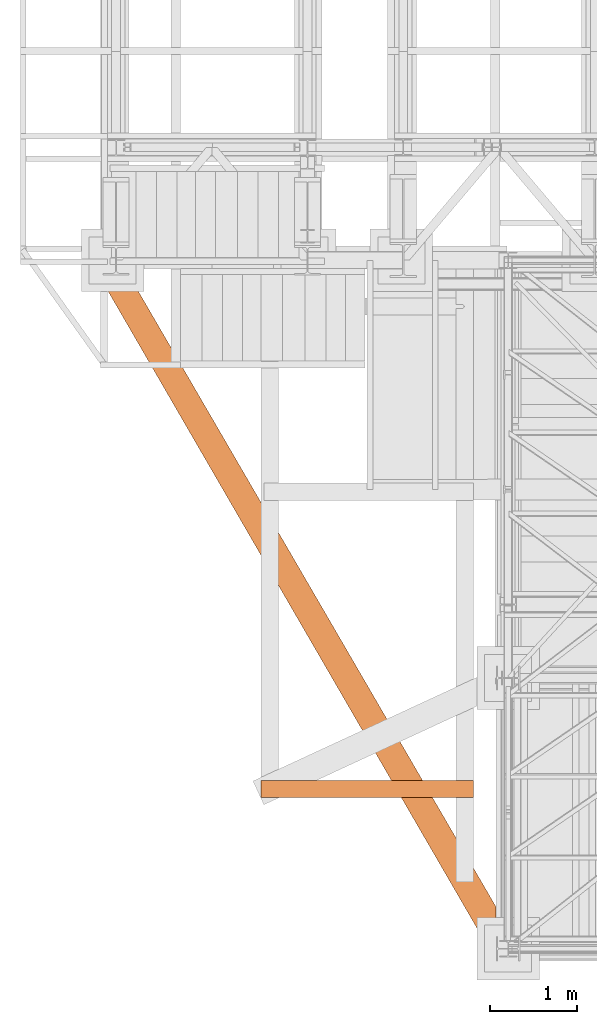
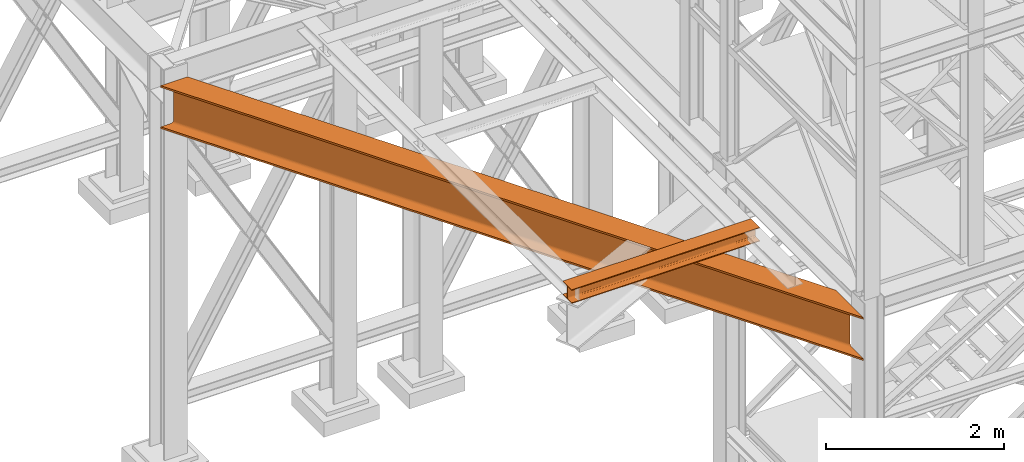
# One storey, part 1 of 208: 2 proxies.
"""IFC2X3 building model written with IfcOpenShell, lengths in millimetres."""

from ifc_helpers import new_model, entity, si_unit, converted_unit, frame, origin, origin_with_axes, place, context, subcontext, project, spatial, faceted_brep, element, save


model = new_model("IFC2X3")

# Units and contexts
model_context = context("Model", 3, precision=1e-05, world=origin())
plan_context = context("Plan", 3, precision=1e-05, world=origin())
body_context = subcontext(model_context, "Body", "Model", "MODEL_VIEW")
ifc_project = project(units=[si_unit("LENGTHUNIT", "METRE", prefix="MILLI"), converted_unit("PLANEANGLEUNIT", "DEGREE", entity("IfcPlaneAngleMeasure", 0.0174532925199433), si_unit("PLANEANGLEUNIT", "RADIAN"), dimensions=[0, 0, 0, 0, 0, 0, 0]), si_unit("AREAUNIT", "SQUARE_METRE"), si_unit("VOLUMEUNIT", "CUBIC_METRE")], contexts=[model_context, plan_context])

# Building, storey
building_placement = place(None, origin())
building = spatial("IfcBuilding", under=ifc_project, at=building_placement, CompositionType="COMPLEX")
storey_placement = place(building_placement, origin_with_axes())
storey = spatial("IfcBuildingStorey", under=building, at=storey_placement, Name="Geschoss", CompositionType="ELEMENT")

# Proxies
proxy_1_placement = place(storey_placement, frame((-3505.997718269851, -25312.57439091394, 4504.990005364415), z_axis=(0.0, 0.0, 1.0), x_axis=(1.0, 0.0, 0.0)))
element("IfcBuildingElementProxy", 1, at=proxy_1_placement, inside=storey, context=body_context, shape_type="Brep", body=[
    faceted_brep([(4564.262686202468, 622.7829206339375, 590.0100000000002), (346.9211581445925, 7880.009995598281, 590.0100000000002), (346.9211581445925, 7880.009995598281, 565.0100000000002), (4564.262686202468, 622.7829206339375, 565.0100000000002), (4564.262686202468, 622.7829206339375, 565.0100000000002), (346.9211581445925, 7880.009995598281, 565.0100000000002), (212.1356261913879, 7880.009995598281, 565.0100000000002), (4564.262686202468, 380.9394364544241, 565.0100000000002), (4564.262686202468, 380.9394364544241, 565.0100000000002), (212.1356261913879, 7880.009995598281, 565.0100000000002), (202.5987725171945, 7880.009995598281, 563.7032507142912), (4564.262686202468, 363.6192277572482, 563.6884339422604), (202.486086011646, 7880.009995598281, 563.6884339422604), (193.8785687326563, 7880.009995598281, 559.8945001282118), (4564.262686202468, 347.9943855320853, 559.8534254634023), (193.7814637785159, 7880.009995598281, 559.8534254634023), (186.9478919928752, 7880.009995598281, 553.9417684022137), (4564.262686202468, 335.5944568794512, 553.8801750658013), (186.8737043222827, 7880.009995598281, 553.8801750658013), (182.4852673949699, 7880.009995598281, 546.4290967956804), (4564.262686202469, 327.6333254426718, 546.3534305458606), (182.4388328598234, 7880.009995598281, 546.3534305458606), (180.9264244528931, 7880.009995598281, 538.0930942108116), (4564.262686202468, 324.8898735973708, 538.0100000000002), (180.9105722931872, 7880.009995598281, 538.0100000000002), (180.9105722931872, 7880.009995598281, 52.01000000000022), (4564.262686202468, 324.8898735973708, 52.01000000000022), (4564.262686202468, 324.8898735973708, 52.01000000000022), (180.9105722931872, 7880.009995598281, 52.01000000000022), (182.4228536955015, 7880.009995598281, 43.75032818788168), (4564.262686202469, 327.6333254426718, 43.66656945413979), (182.4388328598234, 7880.009995598281, 43.66656945413979), (186.8262006717232, 7880.009995598281, 36.21723007892069), (4564.262686202468, 335.5944568794512, 36.13982493419917), (186.8737043222827, 7880.009995598281, 36.13982493419917), (193.7046841579395, 7880.009995598281, 30.23031562115921), (4564.262686202469, 347.9943855320853, 30.16657453659809), (193.7814637785159, 7880.009995598281, 30.16657453659809), (202.384869361942, 7880.009995598281, 26.37437638797292), (4564.262686202468, 363.6192277572482, 26.33156605774093), (202.486086011646, 7880.009995598281, 26.33156605774093), (212.0178928223504, 7880.009995598281, 25.02547893943847), (4564.262686202468, 380.9394364544241, 25.01000000000022), (212.1356261913879, 7880.009995598281, 25.01000000000022), (346.9211581445925, 7880.009995598281, 25.01000000000022), (4564.262686202468, 622.7829206339411, 25.01000000000022), (4564.262686202468, 622.7829206339411, 25.01000000000022), (346.9211581445925, 7880.009995598281, 25.01000000000022), (346.9211581445925, 7880.009995598281, 0.01000000000021828), (4564.262686202468, 622.7829206339375, 0.01000000000021828), (4564.262686202468, 622.7829206339375, 0.01000000000021828), (346.9211581445925, 7880.009995598281, 0.01000000000021828), (0.01000000000021828, 7880.009995598281, 0.01000000000021828), (4564.262686202468, 0.01000000000203727, 0.01000000000021828), (4564.262686202468, 0.01000000000203727, 0.01000000000021828), (0.01000000000021828, 7880.009995598281, 0.01000000000021828), (0.01000000000021828, 7880.009995598281, 25.01000000000022), (4564.262686202468, 0.01000000000203727, 25.01000000000022), (4564.262686202468, 0.01000000000203727, 25.01000000000022), (0.01000000000021828, 7880.009995598281, 25.01000000000022), (134.6597476393436, 7880.009995598281, 25.01000000000022), (4564.262686202468, 241.8534841795117, 25.01000000000022), (4564.262686202468, 241.8534841795117, 25.01000000000022), (134.6597476393436, 7880.009995598281, 25.01000000000022), (144.2271042825123, 7880.009995598281, 26.32116263985427), (4564.262686202469, 259.1736928766877, 26.33156605774093), (144.3061822778, 7880.009995598281, 26.33156605774093), (152.9329818816095, 7880.009995598281, 30.13450818402725), (4564.262686202468, 274.7985351018506, 30.16657453659809), (153.0087610158716, 7880.009995598281, 30.16657453659809), (159.8524497735762, 7880.009995598281, 36.08753934009383), (4564.262686202468, 287.1984637544883, 36.13982493419917), (159.9154104590762, 7880.009995598281, 36.13982493419917), (164.308205835936, 7880.009995598281, 43.59876618566887), (4564.262686202469, 295.1595951912641, 43.66656945413979), (164.3498079410019, 7880.009995598281, 43.66656945413979), (165.863464784421, 7880.009995598281, 51.93406860522919), (4564.262686202468, 297.9030470365688, 52.01000000000113), (165.8779484128099, 7880.009995598281, 52.01000000000113), (165.8779484128118, 7880.009995598281, 538.0100000000002), (4564.262686202468, 297.9030470365688, 538.0100000000002), (4564.262686202468, 297.9030470365688, 538.0100000000002), (165.8779484128118, 7880.009995598281, 538.0100000000002), (164.3641643242863, 7880.009995598281, 546.2781651586538), (4564.262686202468, 295.1595951912677, 546.3534305458606), (164.3498079410019, 7880.009995598281, 546.3534305458606), (159.95594069441, 7880.009995598281, 553.8141159781535), (4564.262686202468, 287.1984637544883, 553.8801750658013), (159.9154104590762, 7880.009995598281, 553.8801750658013), (153.0691197044253, 7880.009995598281, 559.8032974416956), (4564.262686202468, 274.7985351018506, 559.8534254634023), (153.0087610158716, 7880.009995598281, 559.8534254634023), (144.3778264089979, 7880.009995598281, 563.6581148673704), (4564.262686202469, 259.1736928766877, 563.6884339422604), (144.3061822778, 7880.009995598281, 563.6884339422604), (134.7337395040158, 7880.009995598281, 565.0002648312957), (4564.262686202468, 241.8534841795117, 565.0100000000002), (134.6597476393436, 7880.009995598281, 565.0100000000002), (0.01000000000021828, 7880.009995598281, 565.0100000000002), (4564.262686202468, 0.01000000000203727, 565.0100000000002), (4564.262686202468, 0.01000000000203727, 565.0100000000002), (0.01000000000021828, 7880.009995598281, 565.0100000000002), (0.01000000000021828, 7880.009995598281, 590.0100000000002), (4564.262686202468, 0.01000000000203727, 590.0100000000002), (4564.262686202468, 0.01000000000203727, 590.0100000000002), (0.01000000000021828, 7880.009995598281, 590.0100000000002), (346.9211581445925, 7880.009995598281, 590.0100000000002), (4564.262686202468, 622.7829206339375, 590.0100000000002), (4564.262686202468, 0.01000000000203727, 0.01000000000021828), (4564.262686202468, 0.01000000000203727, 25.01000000000022), (4564.262686202468, 241.8534841795117, 25.01000000000022), (4564.262686202469, 259.1736928766877, 26.33156605774093), (4564.262686202468, 274.7985351018506, 30.16657453659809), (4564.262686202468, 287.1984637544883, 36.13982493419917), (4564.262686202469, 295.1595951912641, 43.66656945413979), (4564.262686202468, 297.9030470365688, 52.01000000000113), (4564.262686202468, 297.9030470365688, 538.0100000000002), (4564.262686202468, 295.1595951912677, 546.3534305458606), (4564.262686202468, 287.1984637544883, 553.8801750658013), (4564.262686202468, 274.7985351018506, 559.8534254634023), (4564.262686202469, 259.1736928766877, 563.6884339422604), (4564.262686202468, 241.8534841795117, 565.0100000000002), (4564.262686202468, 0.01000000000203727, 565.0100000000002), (4564.262686202468, 0.01000000000203727, 590.0100000000002), (4564.262686202468, 622.7829206339375, 590.0100000000002), (4564.262686202468, 622.7829206339375, 565.0100000000002), (4564.262686202468, 380.9394364544241, 565.0100000000002), (4564.262686202468, 363.6192277572482, 563.6884339422604), (4564.262686202468, 347.9943855320853, 559.8534254634023), (4564.262686202468, 335.5944568794512, 553.8801750658013), (4564.262686202469, 327.6333254426718, 546.3534305458606), (4564.262686202468, 324.8898735973708, 538.0100000000002), (4564.262686202468, 324.8898735973708, 52.01000000000022), (4564.262686202469, 327.6333254426718, 43.66656945413979), (4564.262686202468, 335.5944568794512, 36.13982493419917), (4564.262686202469, 347.9943855320853, 30.16657453659809), (4564.262686202468, 363.6192277572482, 26.33156605774093), (4564.262686202468, 380.9394364544241, 25.01000000000022), (4564.262686202468, 622.7829206339411, 25.01000000000022), (4564.262686202468, 622.7829206339375, 0.01000000000021828), (202.486086011646, 7880.009995598281, 563.6884339422604), (4564.262686202468, 363.6192277572482, 563.6884339422604), (4564.262686202468, 380.9394364544241, 565.0100000000002), (202.5987725171945, 7880.009995598281, 563.7032507142912), (193.7814637785159, 7880.009995598281, 559.8534254634023), (4564.262686202468, 347.9943855320853, 559.8534254634023), (4564.262686202468, 363.6192277572482, 563.6884339422604), (193.8785687326563, 7880.009995598281, 559.8945001282118), (186.8737043222827, 7880.009995598281, 553.8801750658013), (4564.262686202468, 335.5944568794512, 553.8801750658013), (4564.262686202468, 347.9943855320853, 559.8534254634023), (186.9478919928752, 7880.009995598281, 553.9417684022137), (182.4388328598234, 7880.009995598281, 546.3534305458606), (4564.262686202469, 327.6333254426718, 546.3534305458606), (4564.262686202468, 335.5944568794512, 553.8801750658013), (182.4852673949699, 7880.009995598281, 546.4290967956804), (180.9105722931872, 7880.009995598281, 538.0100000000002), (4564.262686202468, 324.8898735973708, 538.0100000000002), (4564.262686202469, 327.6333254426718, 546.3534305458606), (180.9264244528931, 7880.009995598281, 538.0930942108116), (182.4388328598234, 7880.009995598281, 43.66656945413979), (4564.262686202469, 327.6333254426718, 43.66656945413979), (4564.262686202468, 324.8898735973708, 52.01000000000022), (182.4228536955015, 7880.009995598281, 43.75032818788168), (186.8737043222827, 7880.009995598281, 36.13982493419917), (4564.262686202468, 335.5944568794512, 36.13982493419917), (4564.262686202469, 327.6333254426718, 43.66656945413979), (186.8262006717232, 7880.009995598281, 36.21723007892069), (193.7814637785159, 7880.009995598281, 30.16657453659809), (4564.262686202469, 347.9943855320853, 30.16657453659809), (4564.262686202468, 335.5944568794512, 36.13982493419917), (193.7046841579395, 7880.009995598281, 30.23031562115921), (202.486086011646, 7880.009995598281, 26.33156605774093), (4564.262686202468, 363.6192277572482, 26.33156605774093), (4564.262686202469, 347.9943855320853, 30.16657453659809), (202.384869361942, 7880.009995598281, 26.37437638797292), (212.1356261913879, 7880.009995598281, 25.01000000000022), (4564.262686202468, 380.9394364544241, 25.01000000000022), (4564.262686202468, 363.6192277572482, 26.33156605774093), (212.0178928223504, 7880.009995598281, 25.02547893943847), (144.3061822778, 7880.009995598281, 26.33156605774093), (4564.262686202469, 259.1736928766877, 26.33156605774093), (4564.262686202468, 241.8534841795117, 25.01000000000022), (144.2271042825123, 7880.009995598281, 26.32116263985427), (153.0087610158716, 7880.009995598281, 30.16657453659809), (4564.262686202468, 274.7985351018506, 30.16657453659809), (4564.262686202469, 259.1736928766877, 26.33156605774093), (152.9329818816095, 7880.009995598281, 30.13450818402725), (159.9154104590762, 7880.009995598281, 36.13982493419917), (4564.262686202468, 287.1984637544883, 36.13982493419917), (4564.262686202468, 274.7985351018506, 30.16657453659809), (159.8524497735762, 7880.009995598281, 36.08753934009383), (164.3498079410019, 7880.009995598281, 43.66656945413979), (4564.262686202469, 295.1595951912641, 43.66656945413979), (4564.262686202468, 287.1984637544883, 36.13982493419917), (164.308205835936, 7880.009995598281, 43.59876618566887), (165.8779484128099, 7880.009995598281, 52.01000000000113), (4564.262686202468, 297.9030470365688, 52.01000000000113), (4564.262686202469, 295.1595951912641, 43.66656945413979), (165.863464784421, 7880.009995598281, 51.93406860522919), (164.3498079410019, 7880.009995598281, 546.3534305458606), (4564.262686202468, 295.1595951912677, 546.3534305458606), (4564.262686202468, 297.9030470365688, 538.0100000000002), (164.3641643242863, 7880.009995598281, 546.2781651586538), (159.9154104590762, 7880.009995598281, 553.8801750658013), (4564.262686202468, 287.1984637544883, 553.8801750658013), (4564.262686202468, 295.1595951912677, 546.3534305458606), (159.95594069441, 7880.009995598281, 553.8141159781535), (153.0087610158716, 7880.009995598281, 559.8534254634023), (4564.262686202468, 274.7985351018506, 559.8534254634023), (4564.262686202468, 287.1984637544883, 553.8801750658013), (153.0691197044253, 7880.009995598281, 559.8032974416956), (144.3061822778, 7880.009995598281, 563.6884339422604), (4564.262686202469, 259.1736928766877, 563.6884339422604), (4564.262686202468, 274.7985351018506, 559.8534254634023), (144.3778264089979, 7880.009995598281, 563.6581148673704), (134.6597476393436, 7880.009995598281, 565.0100000000002), (4564.262686202468, 241.8534841795117, 565.0100000000002), (4564.262686202469, 259.1736928766877, 563.6884339422604), (134.7337395040158, 7880.009995598281, 565.0002648312957), (346.9211581445925, 7880.009995598281, 590.0100000000002), (0.01000000000021828, 7880.009995598281, 590.0100000000002), (0.01000000000021828, 7880.009995598281, 565.0100000000002), (134.6597476393436, 7880.009995598281, 565.0100000000002), (134.7337395040158, 7880.009995598281, 565.0002648312957), (144.3061822778, 7880.009995598281, 563.6884339422604), (144.3778264089979, 7880.009995598281, 563.6581148673704), (153.0087610158716, 7880.009995598281, 559.8534254634023), (153.0691197044253, 7880.009995598281, 559.8032974416956), (159.9154104590762, 7880.009995598281, 553.8801750658013), (159.95594069441, 7880.009995598281, 553.8141159781535), (164.3498079410019, 7880.009995598281, 546.3534305458606), (164.3641643242863, 7880.009995598281, 546.2781651586538), (165.8779484128118, 7880.009995598281, 538.0100000000002), (165.8779484128099, 7880.009995598281, 52.01000000000113), (165.863464784421, 7880.009995598281, 51.93406860522919), (164.3498079410019, 7880.009995598281, 43.66656945413979), (164.308205835936, 7880.009995598281, 43.59876618566887), (159.9154104590762, 7880.009995598281, 36.13982493419917), (159.8524497735762, 7880.009995598281, 36.08753934009383), (153.0087610158716, 7880.009995598281, 30.16657453659809), (152.9329818816095, 7880.009995598281, 30.13450818402725), (144.3061822778, 7880.009995598281, 26.33156605774093), (144.2271042825123, 7880.009995598281, 26.32116263985427), (134.6597476393436, 7880.009995598281, 25.01000000000022), (0.01000000000021828, 7880.009995598281, 25.01000000000022), (0.01000000000021828, 7880.009995598281, 0.01000000000021828), (346.9211581445925, 7880.009995598281, 0.01000000000021828), (346.9211581445925, 7880.009995598281, 25.01000000000022), (212.1356261913879, 7880.009995598281, 25.01000000000022), (212.0178928223504, 7880.009995598281, 25.02547893943847), (202.486086011646, 7880.009995598281, 26.33156605774093), (202.384869361942, 7880.009995598281, 26.37437638797292), (193.7814637785159, 7880.009995598281, 30.16657453659809), (193.7046841579395, 7880.009995598281, 30.23031562115921), (186.8737043222827, 7880.009995598281, 36.13982493419917), (186.8262006717232, 7880.009995598281, 36.21723007892069), (182.4388328598234, 7880.009995598281, 43.66656945413979), (182.4228536955015, 7880.009995598281, 43.75032818788168), (180.9105722931872, 7880.009995598281, 52.01000000000022), (180.9105722931872, 7880.009995598281, 538.0100000000002), (180.9264244528931, 7880.009995598281, 538.0930942108116), (182.4388328598234, 7880.009995598281, 546.3534305458606), (182.4852673949699, 7880.009995598281, 546.4290967956804), (186.8737043222827, 7880.009995598281, 553.8801750658013), (186.9478919928752, 7880.009995598281, 553.9417684022137), (193.7814637785159, 7880.009995598281, 559.8534254634023), (193.8785687326563, 7880.009995598281, 559.8945001282118), (202.486086011646, 7880.009995598281, 563.6884339422604), (202.5987725171945, 7880.009995598281, 563.7032507142912), (212.1356261913879, 7880.009995598281, 565.0100000000002), (346.9211581445925, 7880.009995598281, 565.0100000000002)], [[[0, 1, 2, 3]], [[4, 5, 6, 7]], [[8, 9, 10]], [[11, 12, 13]], [[14, 15, 16]], [[17, 18, 19]], [[20, 21, 22]], [[23, 24, 25, 26]], [[27, 28, 29]], [[30, 31, 32]], [[33, 34, 35]], [[36, 37, 38]], [[39, 40, 41]], [[42, 43, 44, 45]], [[46, 47, 48, 49]], [[50, 51, 52, 53]], [[54, 55, 56, 57]], [[58, 59, 60, 61]], [[62, 63, 64]], [[65, 66, 67]], [[68, 69, 70]], [[71, 72, 73]], [[74, 75, 76]], [[77, 78, 79, 80]], [[81, 82, 83]], [[84, 85, 86]], [[87, 88, 89]], [[90, 91, 92]], [[93, 94, 95]], [[96, 97, 98, 99]], [[100, 101, 102, 103]], [[104, 105, 106, 107]], [[108, 109, 110, 111, 112, 113, 114, 115, 116, 117, 118, 119, 120, 121, 122, 123, 124, 125, 126, 127, 128, 129, 130, 131, 132, 133, 134, 135, 136, 137, 138, 139]], [[140, 141, 142, 143]], [[144, 145, 146, 147]], [[148, 149, 150, 151]], [[152, 153, 154, 155]], [[156, 157, 158, 159]], [[160, 161, 162, 163]], [[164, 165, 166, 167]], [[168, 169, 170, 171]], [[172, 173, 174, 175]], [[176, 177, 178, 179]], [[180, 181, 182, 183]], [[184, 185, 186, 187]], [[188, 189, 190, 191]], [[192, 193, 194, 195]], [[196, 197, 198, 199]], [[200, 201, 202, 203]], [[204, 205, 206, 207]], [[208, 209, 210, 211]], [[212, 213, 214, 215]], [[216, 217, 218, 219]], [[220, 221, 222, 223, 224, 225, 226, 227, 228, 229, 230, 231, 232, 233, 234, 235, 236, 237, 238, 239, 240, 241, 242, 243, 244, 245, 246, 247, 248, 249, 250, 251, 252, 253, 254, 255, 256, 257, 258, 259, 260, 261, 262, 263, 264, 265, 266, 267, 268, 269, 270, 271]]], orient=[[False], [False], [False], [False], [False], [False], [False], [False], [False], [False], [False], [False], [False], [False], [False], [False], [False], [False], [False], [False], [False], [False], [False], [False], [False], [False], [False], [False], [False], [False], [False], [False], [False], [False], [False], [False], [False], [False], [False], [False], [False], [False], [False], [False], [False], [False], [False], [False], [False], [False], [False], [False], [False], [False]]),
])
proxy_2_placement = place(storey_placement, frame((-1641.745031471339, -23437.50386180536, 5094.990005364416), z_axis=(0.0, 0.0, 1.0), x_axis=(1.0, 0.0, 0.0)))
element("IfcBuildingElementProxy", 2, at=proxy_2_placement, inside=storey, context=body_context, shape_type="Brep", body=[
    faceted_brep([(0.01000000000180989, 200.0099999999984, 0.01000000000021828), (2440.01, 200.0099999999984, 0.01000000000021828), (2440.01, 200.0099999999984, 10.01000000000022), (0.01000000000180989, 200.0099999999984, 10.01000000000022), (0.01000000000180989, 200.0099999999984, 10.01000000000022), (2440.01, 200.0099999999984, 10.01000000000022), (2440.01, 121.2599999999766, 10.01000000000022), (0.01000000000180989, 121.2599999999948, 10.01000000000022), (0.01000000000180989, 78.75999999999476, 10.01000000000022), (2440.010000000002, 78.75999999997657, 10.01000000000022), (2440.01, 0.00999999999839929, 10.01000000000022), (0.01000000000180989, 0.00999999999839929, 10.01000000000022), (0.01000000000180989, 121.2599999999948, 10.01000000000022), (2440.01, 121.2599999999766, 10.01000000000022), (2440.01, 115.6977129694024, 10.89104403849342), (0.01000000000180989, 115.6977129694242, 10.89104403849342), (0.01000000000180989, 115.6977129694242, 10.89104403849342), (2440.01, 115.6977129694024, 10.89104403849342), (2440.01, 110.6798832894419, 13.44771635773213), (0.01000000000180989, 110.6798832894601, 13.44771635773213), (0.01000000000180989, 110.6798832894601, 13.44771635773213), (2440.01, 110.6798832894419, 13.44771635773213), (2436.57228364227, 106.6977163577321, 17.42988328946558), (0.01000000000180989, 106.6977163577321, 17.42988328946558), (0.01000000000180989, 106.6977163577321, 17.42988328946558), (2436.57228364227, 106.6977163577321, 17.42988328946558), (2439.128955961505, 104.1410440384934, 22.44771296942599), (0.01000000000180989, 104.1410440384934, 22.44771296942599), (0.01000000000180989, 104.1410440384934, 22.44771296942599), (2439.128955961505, 104.1410440384934, 22.44771296942599), (2440.01, 103.2599999999984, 28.01000000000022), (0.01000000000180989, 103.2599999999984, 28.01000000000022), (0.01000000000180989, 103.2599999999984, 28.01000000000022), (2440.01, 103.2599999999984, 28.01000000000022), (2440.01, 103.2599999999984, 162.0100000000002), (0.01000000000180989, 103.2599999999984, 162.0100000000002), (0.01000000000180989, 103.2599999999984, 162.0100000000002), (2440.01, 103.2599999999984, 162.0100000000002), (2439.128955961505, 104.1410440384934, 167.5722870305744), (0.01000000000362888, 104.1410440384934, 167.5722870305744), (0.01000000000362888, 104.1410440384934, 167.5722870305744), (2439.128955961505, 104.1410440384934, 167.5722870305744), (2436.57228364227, 106.6977163577321, 172.5901167105349), (0.01000000000180989, 106.6977163577321, 172.5901167105349), (0.01000000000180989, 106.6977163577321, 172.5901167105349), (2436.57228364227, 106.6977163577321, 172.5901167105349), (2440.01, 110.6798832894419, 176.5722836422683), (0.01000000000180989, 110.6798832894601, 176.5722836422683), (0.01000000000180989, 110.6798832894601, 176.5722836422683), (2440.01, 110.6798832894419, 176.5722836422683), (2440.01, 115.6977129694024, 179.128955961507), (0.01000000000180989, 115.6977129694242, 179.128955961507), (0.01000000000180989, 115.6977129694242, 179.128955961507), (2440.01, 115.6977129694024, 179.128955961507), (2440.010000000002, 120.0099999999766, 180.0100000000002), (0.01000000000362888, 120.0099999999948, 180.0100000000002), (0.01000000000362888, 120.0099999999948, 180.0100000000002), (2440.010000000002, 120.0099999999766, 180.0100000000002), (2440.01, 200.0099999999984, 180.0100000000011), (0.01000000000180989, 200.0099999999984, 180.0100000000002), (2440.010000000002, 78.75999999997657, 180.0100000000011), (0.01000000000180989, 78.75999999999476, 180.0100000000002), (0.01000000000180989, 0.00999999999839929, 180.0099999999993), (2440.01, 0.00999999999839929, 180.0100000000002), (0.01000000000180989, 200.0099999999984, 180.0100000000002), (2440.01, 200.0099999999984, 180.0100000000011), (2440.01, 200.0099999999984, 190.0100000000002), (0.01000000000180989, 200.0099999999984, 190.0100000000002), (0.01000000000180989, 200.0099999999984, 190.0100000000002), (2440.01, 200.0099999999984, 190.0100000000002), (2440.01, 0.00999999999839929, 190.0100000000002), (0.01000000000180989, 0.00999999999839929, 190.0100000000002), (0.01000000000180989, 0.00999999999839929, 190.0100000000002), (2440.01, 0.00999999999839929, 190.0100000000002), (2440.01, 0.00999999999839929, 180.0100000000002), (0.01000000000180989, 0.00999999999839929, 180.0099999999993), (0.01000000000180989, 78.75999999999476, 180.0100000000002), (2440.010000000002, 78.75999999997657, 180.0100000000011), (2440.01, 84.3222870305508, 179.128955961507), (0.01000000000180989, 84.32228703057262, 179.128955961507), (0.01000000000180989, 84.32228703057262, 179.128955961507), (2440.01, 84.3222870305508, 179.128955961507), (2440.01, 89.34011671051121, 176.5722836422683), (0.009999999999990905, 89.3401167105294, 176.5722836422683), (0.009999999999990905, 89.3401167105294, 176.5722836422683), (2440.01, 89.34011671051121, 176.5722836422683), (2436.57228364227, 93.3222836422683, 172.5901167105349), (0.01000000000180989, 93.3222836422683, 172.5901167105349), (0.01000000000180989, 93.3222836422683, 172.5901167105349), (2436.57228364227, 93.3222836422683, 172.5901167105349), (2439.128955961505, 95.87895596150338, 167.5722870305744), (0.01000000000180989, 95.87895596150338, 167.5722870305744), (0.01000000000180989, 95.87895596150338, 167.5722870305744), (2439.128955961505, 95.87895596150338, 167.5722870305744), (2440.01, 96.7599999999984, 162.0100000000002), (0.01000000000180989, 96.7599999999984, 162.0100000000002), (0.01000000000180989, 96.7599999999984, 162.0100000000002), (2440.01, 96.7599999999984, 162.0100000000002), (2440.01, 96.7599999999984, 28.01000000000022), (0.01000000000180989, 96.7599999999984, 28.01000000000022), (0.01000000000180989, 96.7599999999984, 28.01000000000022), (2440.01, 96.7599999999984, 28.01000000000022), (2439.128955961505, 95.87895596150338, 22.44771296942599), (0.01000000000180989, 95.87895596150338, 22.44771296942599), (0.01000000000180989, 95.87895596150338, 22.44771296942599), (2439.128955961505, 95.87895596150338, 22.44771296942599), (2436.57228364227, 93.3222836422683, 17.42988328946649), (0.01000000000180989, 93.3222836422683, 17.42988328946558), (0.01000000000180989, 93.3222836422683, 17.42988328946558), (2436.57228364227, 93.3222836422683, 17.42988328946649), (2440.01, 89.34011671051121, 13.44771635773213), (0.01000000000180989, 89.3401167105294, 13.44771635773213), (0.01000000000180989, 89.3401167105294, 13.44771635773213), (2440.01, 89.34011671051121, 13.44771635773213), (2440.01, 84.3222870305508, 10.89104403849342), (0.01000000000180989, 84.32228703057262, 10.89104403849342), (0.01000000000180989, 84.32228703057262, 10.89104403849342), (2440.01, 84.3222870305508, 10.89104403849342), (2440.010000000002, 78.75999999997657, 10.01000000000022), (0.01000000000180989, 78.75999999999476, 10.01000000000022), (0.01000000000180989, 0.00999999999839929, 10.01000000000022), (2440.01, 0.00999999999839929, 10.01000000000022), (2440.01, 0.00999999999839929, 0.009999999999308784), (0.01000000000180989, 0.00999999999839929, 0.01000000000021828), (0.01000000000180989, 0.00999999999839929, 0.01000000000021828), (2440.01, 0.00999999999839929, 0.009999999999308784), (2440.01, 200.0099999999984, 0.01000000000021828), (0.01000000000180989, 200.0099999999984, 0.01000000000021828), (2440.01, 96.7599999999984, 28.01000000000022), (2440.01, 96.7599999999984, 162.0100000000002), (2440.01, 103.2599999999984, 162.0100000000002), (2440.01, 103.2599999999984, 28.01000000000022), (2440.01, 200.0099999999984, 190.0100000000002), (2440.01, 200.0099999999984, 180.0100000000011), (2440.010000000002, 120.0099999999766, 180.0100000000002), (2440.01, 115.6977129694024, 179.128955961507), (2440.01, 110.6798832894419, 176.5722836422683), (2440.01, 89.34011671051121, 176.5722836422683), (2440.01, 84.3222870305508, 179.128955961507), (2440.010000000002, 78.75999999997657, 180.0100000000011), (2440.01, 0.00999999999839929, 180.0100000000002), (2440.01, 0.00999999999839929, 190.0100000000002), (2440.01, 110.6798832894419, 176.5722836422683), (2436.57228364227, 106.6977163577321, 172.5901167105349), (2436.57228364227, 93.3222836422683, 172.5901167105349), (2440.01, 89.34011671051121, 176.5722836422683), (2436.57228364227, 106.6977163577321, 172.5901167105349), (2439.128955961505, 104.1410440384934, 167.5722870305744), (2439.128955961505, 95.87895596150338, 167.5722870305744), (2436.57228364227, 93.3222836422683, 172.5901167105349), (2439.128955961505, 104.1410440384934, 167.5722870305744), (2440.01, 103.2599999999984, 162.0100000000002), (2440.01, 96.7599999999984, 162.0100000000002), (2439.128955961505, 95.87895596150338, 167.5722870305744), (2440.01, 103.2599999999984, 28.01000000000022), (2439.128955961505, 104.1410440384934, 22.44771296942599), (2439.128955961505, 95.87895596150338, 22.44771296942599), (2440.01, 96.7599999999984, 28.01000000000022), (2439.128955961505, 104.1410440384934, 22.44771296942599), (2436.57228364227, 106.6977163577321, 17.42988328946558), (2436.57228364227, 93.3222836422683, 17.42988328946649), (2439.128955961505, 95.87895596150338, 22.44771296942599), (2436.57228364227, 106.6977163577321, 17.42988328946558), (2440.01, 110.6798832894419, 13.44771635773213), (2440.01, 89.34011671051121, 13.44771635773213), (2436.57228364227, 93.3222836422683, 17.42988328946649), (2440.01, 110.6798832894419, 13.44771635773213), (2440.01, 115.6977129694024, 10.89104403849342), (2440.01, 121.2599999999766, 10.01000000000022), (2440.01, 200.0099999999984, 10.01000000000022), (2440.01, 200.0099999999984, 0.01000000000021828), (2440.01, 0.00999999999839929, 0.009999999999308784), (2440.01, 0.00999999999839929, 10.01000000000022), (2440.010000000002, 78.75999999997657, 10.01000000000022), (2440.01, 84.3222870305508, 10.89104403849342), (2440.01, 89.34011671051121, 13.44771635773213), (0.01000000000180989, 0.00999999999839929, 0.01000000000021828), (0.01000000000180989, 200.0099999999984, 0.01000000000021828), (0.01000000000180989, 200.0099999999984, 10.01000000000022), (0.01000000000180989, 121.2599999999948, 10.01000000000022), (0.01000000000180989, 115.6977129694242, 10.89104403849342), (0.01000000000180989, 110.6798832894601, 13.44771635773213), (0.01000000000180989, 106.6977163577321, 17.42988328946558), (0.01000000000180989, 104.1410440384934, 22.44771296942599), (0.01000000000180989, 103.2599999999984, 28.01000000000022), (0.01000000000180989, 103.2599999999984, 162.0100000000002), (0.01000000000362888, 104.1410440384934, 167.5722870305744), (0.01000000000180989, 106.6977163577321, 172.5901167105349), (0.01000000000180989, 110.6798832894601, 176.5722836422683), (0.01000000000180989, 115.6977129694242, 179.128955961507), (0.01000000000362888, 120.0099999999948, 180.0100000000002), (0.01000000000180989, 200.0099999999984, 180.0100000000002), (0.01000000000180989, 200.0099999999984, 190.0100000000002), (0.01000000000180989, 0.00999999999839929, 190.0100000000002), (0.01000000000180989, 0.00999999999839929, 180.0099999999993), (0.01000000000180989, 78.75999999999476, 180.0100000000002), (0.01000000000180989, 84.32228703057262, 179.128955961507), (0.009999999999990905, 89.3401167105294, 176.5722836422683), (0.01000000000180989, 93.3222836422683, 172.5901167105349), (0.01000000000180989, 95.87895596150338, 167.5722870305744), (0.01000000000180989, 96.7599999999984, 162.0100000000002), (0.01000000000180989, 96.7599999999984, 28.01000000000022), (0.01000000000180989, 95.87895596150338, 22.44771296942599), (0.01000000000180989, 93.3222836422683, 17.42988328946558), (0.01000000000180989, 89.3401167105294, 13.44771635773213), (0.01000000000180989, 84.32228703057262, 10.89104403849342), (0.01000000000180989, 78.75999999999476, 10.01000000000022), (0.01000000000180989, 0.00999999999839929, 10.01000000000022)], [[[0, 1, 2, 3]], [[4, 5, 6, 7]], [[8, 9, 10, 11]], [[12, 13, 14, 15]], [[16, 17, 18, 19]], [[20, 21, 22, 23]], [[24, 25, 26, 27]], [[28, 29, 30, 31]], [[32, 33, 34, 35]], [[36, 37, 38, 39]], [[40, 41, 42, 43]], [[44, 45, 46, 47]], [[48, 49, 50, 51]], [[52, 53, 54, 55]], [[56, 57, 58, 59]], [[60, 61, 62, 63]], [[64, 65, 66, 67]], [[68, 69, 70, 71]], [[72, 73, 74, 75]], [[76, 77, 78, 79]], [[80, 81, 82, 83]], [[84, 85, 86, 87]], [[88, 89, 90, 91]], [[92, 93, 94, 95]], [[96, 97, 98, 99]], [[100, 101, 102, 103]], [[104, 105, 106, 107]], [[108, 109, 110, 111]], [[112, 113, 114, 115]], [[116, 117, 118, 119]], [[120, 121, 122, 123]], [[124, 125, 126, 127]], [[128, 129, 130, 131]], [[132, 133, 134, 135, 136, 137, 138, 139, 140, 141]], [[142, 143, 144, 145]], [[146, 147, 148, 149]], [[150, 151, 152, 153]], [[154, 155, 156, 157]], [[158, 159, 160, 161]], [[162, 163, 164, 165]], [[166, 167, 168, 169, 170, 171, 172, 173, 174, 175]], [[176, 177, 178, 179, 180, 181, 182, 183, 184, 185, 186, 187, 188, 189, 190, 191, 192, 193, 194, 195, 196, 197, 198, 199, 200, 201, 202, 203, 204, 205, 206, 207]]], orient=[[False], [False], [False], [False], [False], [False], [False], [False], [False], [False], [False], [False], [False], [False], [False], [False], [False], [False], [False], [False], [False], [False], [False], [False], [False], [False], [False], [False], [False], [False], [False], [False], [False], [False], [False], [False], [False], [False], [False], [False], [False], [False]]),
])

save(model, "model.ifc")
